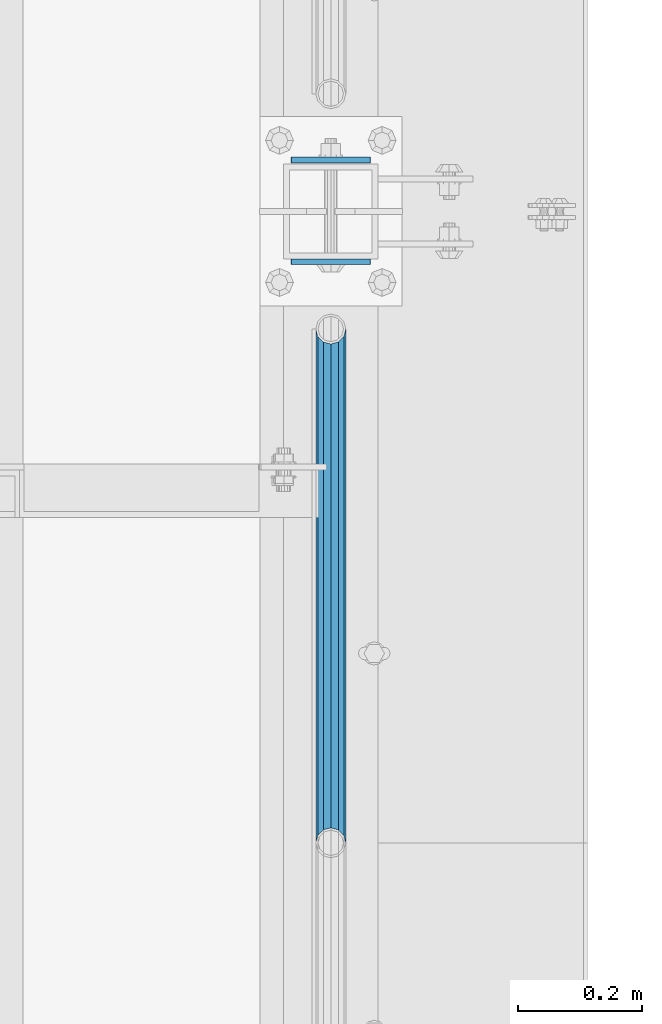
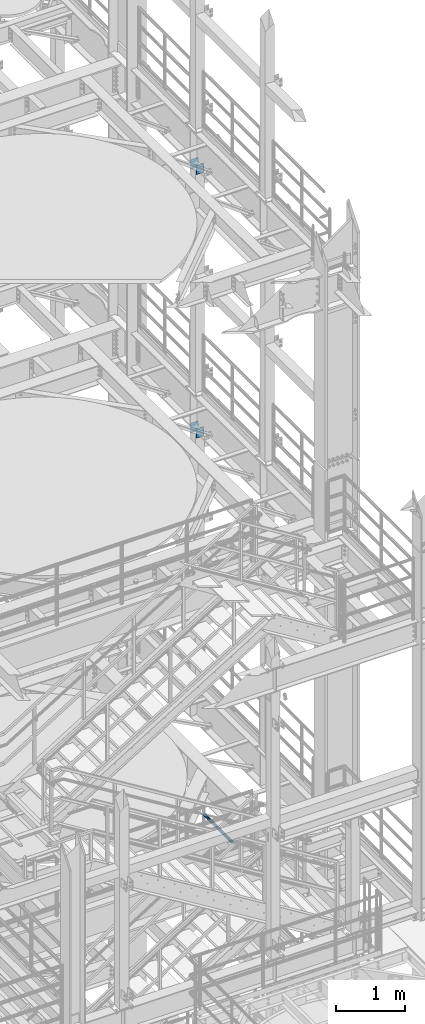
# One storey, part 1266 of 1876: 5 beams, 3 elements without a shape of their own.
"""IFC2X3 building model written with IfcOpenShell, lengths in millimetres."""

from ifc_helpers import new_model, si_unit, frame, origin_with_axes, place, context, subcontext, project, spatial, faceted_brep, material, type_object, element, aggregate, save


model = new_model("IFC2X3")

# Units and contexts
model_context = context("Model", 3, precision=1e-05, world=origin_with_axes())
body_context = subcontext(model_context, "Body", "Model", "MODEL_VIEW")
ifc_project = project(units=[si_unit("LENGTHUNIT", "METRE", prefix="MILLI"), si_unit("AREAUNIT", "SQUARE_METRE"), si_unit("VOLUMEUNIT", "CUBIC_METRE"), si_unit("MASSUNIT", "GRAM", prefix="KILO"), si_unit("TIMEUNIT", "SECOND"), si_unit("PLANEANGLEUNIT", "RADIAN"), si_unit("SOLIDANGLEUNIT", "STERADIAN"), si_unit("THERMODYNAMICTEMPERATUREUNIT", "DEGREE_CELSIUS"), si_unit("LUMINOUSINTENSITYUNIT", "LUMEN")], contexts=[model_context])

# Site, building, storey
site_placement = place(None, origin_with_axes())
site = spatial("IfcSite", under=ifc_project, at=site_placement, CompositionType="ELEMENT")
building_placement = place(site_placement, origin_with_axes())
building = spatial("IfcBuilding", under=site, at=building_placement, Name="Undefined", CompositionType="ELEMENT")
storey_placement = place(building_placement, origin_with_axes())
storey = spatial("IfcBuildingStorey", under=building, at=storey_placement, Name="Undefined", CompositionType="ELEMENT", Elevation=0.0)

# Assembly, beam
assembly_1_placement = place(storey_placement, origin_with_axes())
assembly_1 = element("IfcElementAssembly", 1, at=assembly_1_placement, inside=storey, Name="RAIL", AssemblyPlace="NOTDEFINED", PredefinedType="RIGID_FRAME")
ifc_material_1 = material()
beam_type_1 = type_object("IfcBeamType", Name="PIPE1-1/2SCH40", PredefinedType="NOTDEFINED")
beam_1_placement = place(assembly_1_placement, frame((7620.0, -1524.0, 5902.325), z_axis=(0.0, 0.0, -1.0), x_axis=(0.0, 1.0, 0.0)))
beam_1 = element("IfcBeam", 2, at=beam_1_placement, type_object=beam_type_1, material=ifc_material_1, Name="RAIL", ObjectType="PIPE1-1/2SCH40", context=body_context, shape_type="Brep", body=[
    faceted_brep([(0.0, 24.1299999999992, 0.0), (12.0650000000064, 20.8971929933177, -12.0649999999987), (12.0650000000064, 20.8971929933177, 12.0649999999987), (12.0650000000064, -20.8971929933177, 12.0649999999987), (12.0650000000064, -20.8971929933177, -12.0649999999987), (0.0, -24.1299999999992, 0.0), (20.8971929933249, -12.0650000000005, 20.8971929933177), (20.8971929933249, -12.0650000000005, 15.8661214311796), (15.2545715621445, -17.7076214311801, 10.2235000000001), (12.5151929933249, -20.4470000000001, 0.0), (15.2545715621445, -17.7076214311801, -10.2235000000001), (20.8971929933249, -12.0650000000005, -15.8661214311796), (20.8971929933249, -12.0650000000005, -20.8971929933177), (24.1300000000063, 0.0, -20.4470000000001), (24.1300000000063, 0.0, -24.130000000001), (21.3906214311868, -10.2235000000001, -17.7076214311819), (21.3906214311868, 10.2235000000001, -17.7076214311819), (20.8971929933249, 12.0650000000005, -15.8661214311796), (20.8971929933249, 12.0650000000005, -20.8971929933177), (15.2545715621445, 17.7076214311801, -10.2235000000001), (12.5151929933249, 20.4470000000001, 0.0), (15.2545715621445, 17.7076214311801, 10.2235000000001), (20.8971929933249, 12.0650000000005, 15.8661214311796), (20.8971929933249, 12.0650000000005, 20.8971929933177), (21.3906214311868, 10.2235000000001, 17.7076214311819), (24.1300000000064, 0.0, 20.4470000000001), (24.1300000000064, 0.0, 24.130000000001), (21.3906214311868, -10.2235000000001, 17.7076214311819), (826.77, 24.1300000000001, 0.0), (814.705, 20.8971929933186, -12.0649999999987), (805.872807006681, 12.0649999999996, -20.8971929933177), (826.77, -24.1300000000001, 0.0), (814.705, -20.8971929933186, -12.0649999999987), (814.705, -20.8971929933186, 12.0649999999987), (805.872807006681, -12.0649999999996, 20.8971929933177), (805.872807006681, -12.0649999999996, -20.8971929933177), (802.640000000001, 0.0, -24.130000000001), (805.379378568819, 10.2235000000001, -17.7076214311819), (802.640000000001, 0.0, -20.4470000000001), (805.872807006683, 12.0649999999996, -15.8661214311796), (805.872807006683, -12.0649999999996, -15.8661214311796), (805.379378568819, -10.2235000000001, -17.7076214311819), (811.515428437862, -17.7076214311801, -10.2235000000001), (814.254807006682, -20.4470000000001, 0.0), (811.515428437862, -17.7076214311801, 10.2235000000001), (805.872807006683, -12.0649999999996, 15.8661214311796), (805.379378568819, -10.2235000000001, 17.7076214311819), (802.640000000001, 0.0, 20.4470000000001), (802.640000000001, 0.0, 24.130000000001), (805.872807006681, 12.0649999999996, 20.8971929933177), (814.705, 20.8971929933186, 12.0649999999987), (805.872807006683, 12.0649999999996, 15.8661214311796), (811.515428437862, 17.7076214311801, 10.2235000000001), (814.254807006682, 20.4470000000001, 0.0), (811.515428437862, 17.7076214311801, -10.2235000000001), (805.379378568819, 10.2235000000001, 17.7076214311819)], [[[0, 1, 2]], [[3, 4, 5]], [[6, 7, 8, 9, 10, 11, 12, 4, 3]], [[13, 14, 12, 11, 15]], [[16, 17, 18, 14, 13]], [[2, 1, 18, 17, 19, 20, 21, 22, 23]], [[23, 22, 24, 25, 26]], [[26, 25, 27, 7, 6]], [[1, 0, 28, 29]], [[18, 1, 29, 30]], [[31, 32, 33]], [[6, 3, 33, 34]], [[3, 5, 31, 33]], [[5, 4, 32, 31]], [[4, 12, 35, 32]], [[12, 14, 36, 35]], [[14, 18, 30, 36]], [[37, 38, 36, 30, 39]], [[40, 35, 36, 38, 41]], [[33, 32, 35, 40, 42, 43, 44, 45, 34]], [[34, 45, 46, 47, 48]], [[26, 6, 34, 48]], [[2, 23, 49, 50]], [[23, 26, 48, 49]], [[0, 2, 50, 28]], [[28, 50, 29]], [[49, 51, 52, 53, 54, 39, 30, 29, 50]], [[48, 47, 55, 51, 49]], [[25, 24, 55, 47]], [[55, 24, 22, 21, 52, 51]], [[21, 20, 53, 52]], [[20, 19, 54, 53]], [[19, 17, 16, 37, 39, 54]], [[16, 13, 38, 37]], [[13, 15, 41, 38]], [[41, 15, 11, 10, 42, 40]], [[10, 9, 43, 42]], [[9, 8, 44, 43]], [[8, 7, 27, 46, 45, 44]], [[27, 25, 47, 46]]]),
])
aggregate(assembly_1, [beam_1])

# Assembly, beams
assembly_2_placement = place(storey_placement, origin_with_axes())
assembly_2 = element("IfcElementAssembly", 3, at=assembly_2_placement, inside=storey, Name="BEAM", AssemblyPlace="NOTDEFINED", PredefinedType="RIGID_FRAME")
ifc_material_2 = material(Name="STEEL/A36")
beam_type_2 = type_object("IfcBeamType", PredefinedType="NOTDEFINED")
beam_2_placement = place(assembly_2_placement, frame((7556.36848042001, -425.450000000001, 12604.7488224823), z_axis=(2.95459999824743e-05, 0.0, -0.999999999563517), x_axis=(0.999999999563517, 0.0, 2.95459999828704e-05)))
beam_2 = element("IfcBeam", 4, at=beam_2_placement, type_object=beam_type_2, material=ifc_material_2, Name="PLATE", context=body_context, shape_type="Brep", body=[
    faceted_brep([(0.0, 4.76249999999982, -82.5499999999993), (0.0, 4.76249999999982, 82.5499999999993), (127.0, 4.76249999999982, 82.5499999999993), (127.0, 4.76249999999982, -82.5499999999993), (0.0, -4.76249999999982, 82.5499999999993), (127.0, -4.76249999999982, 82.5499999999993), (0.0, -4.76249999999982, -82.5499999999993), (127.0, -4.76249999999982, -82.5499999999993)], [[[0, 1, 2, 3]], [[1, 4, 5, 2]], [[4, 6, 7, 5]], [[6, 0, 3, 7]], [[5, 7, 3, 2]], [[6, 4, 1, 0]]]),
])
beam_3_placement = place(assembly_2_placement, frame((7556.36848042001, -588.962500000001, 12604.7488224823), z_axis=(2.95459999824743e-05, 0.0, -0.999999999563517), x_axis=(0.999999999563517, 0.0, 2.95459999828704e-05)))
beam_3 = element("IfcBeam", 5, at=beam_3_placement, type_object=beam_type_2, material=ifc_material_2, Name="PLATE", context=body_context, shape_type="Brep", body=[
    faceted_brep([(0.0, 4.76249999999982, -82.5499999999993), (0.0, 4.76249999999982, 82.5499999999993), (127.0, 4.76249999999982, 82.5499999999993), (127.0, 4.76249999999982, -82.5499999999993), (0.0, -4.76249999999982, 82.5499999999993), (127.0, -4.76249999999982, 82.5499999999993), (0.0, -4.76249999999982, -82.5499999999993), (127.0, -4.76249999999982, -82.5499999999993)], [[[0, 1, 2, 3]], [[1, 4, 5, 2]], [[4, 6, 7, 5]], [[6, 0, 3, 7]], [[5, 7, 3, 2]], [[6, 4, 1, 0]]]),
])
aggregate(assembly_2, [beam_2, beam_3])

assembly_3_placement = place(storey_placement, origin_with_axes())
assembly_3 = element("IfcElementAssembly", 6, at=assembly_3_placement, inside=storey, Name="BEAM", AssemblyPlace="NOTDEFINED", PredefinedType="RIGID_FRAME")
beam_4_placement = place(assembly_3_placement, frame((7556.5, -425.450000000001, 17278.35), z_axis=(0.0, 0.0, -1.0), x_axis=(1.0, 0.0, 0.0)))
beam_4 = element("IfcBeam", 7, at=beam_4_placement, type_object=beam_type_2, material=ifc_material_2, Name="PLATE", context=body_context, shape_type="Brep", body=[
    faceted_brep([(0.0, 4.76249999999982, -82.5499999999993), (0.0, 4.76249999999982, 82.5499999999993), (127.0, 4.76249999999982, 82.5499999999993), (127.0, 4.76249999999982, -82.5499999999993), (0.0, -4.76249999999982, 82.5499999999993), (127.0, -4.76249999999982, 82.5499999999993), (0.0, -4.76249999999982, -82.5499999999993), (127.0, -4.76249999999982, -82.5499999999993)], [[[0, 1, 2, 3]], [[1, 4, 5, 2]], [[4, 6, 7, 5]], [[6, 0, 3, 7]], [[5, 7, 3, 2]], [[6, 4, 1, 0]]]),
])
beam_5_placement = place(assembly_3_placement, frame((7556.5, -588.962500000001, 17278.35), z_axis=(0.0, 0.0, -1.0), x_axis=(1.0, 0.0, 0.0)))
beam_5 = element("IfcBeam", 8, at=beam_5_placement, type_object=beam_type_2, material=ifc_material_2, Name="PLATE", context=body_context, shape_type="Brep", body=[
    faceted_brep([(0.0, 4.76249999999982, -82.5499999999993), (0.0, 4.76249999999982, 82.5499999999993), (127.0, 4.76249999999982, 82.5499999999993), (127.0, 4.76249999999982, -82.5499999999993), (0.0, -4.76249999999982, 82.5499999999993), (127.0, -4.76249999999982, 82.5499999999993), (0.0, -4.76249999999982, -82.5499999999993), (127.0, -4.76249999999982, -82.5499999999993)], [[[0, 1, 2, 3]], [[1, 4, 5, 2]], [[4, 6, 7, 5]], [[6, 0, 3, 7]], [[5, 7, 3, 2]], [[6, 4, 1, 0]]]),
])
aggregate(assembly_3, [beam_4, beam_5])

save(model, "model.ifc")
